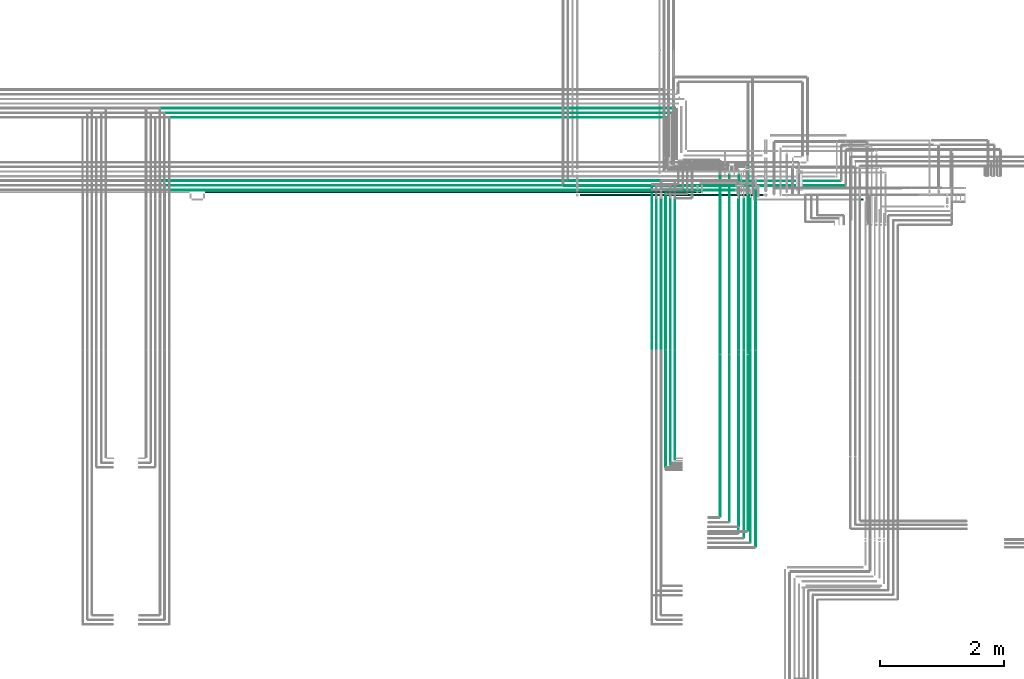
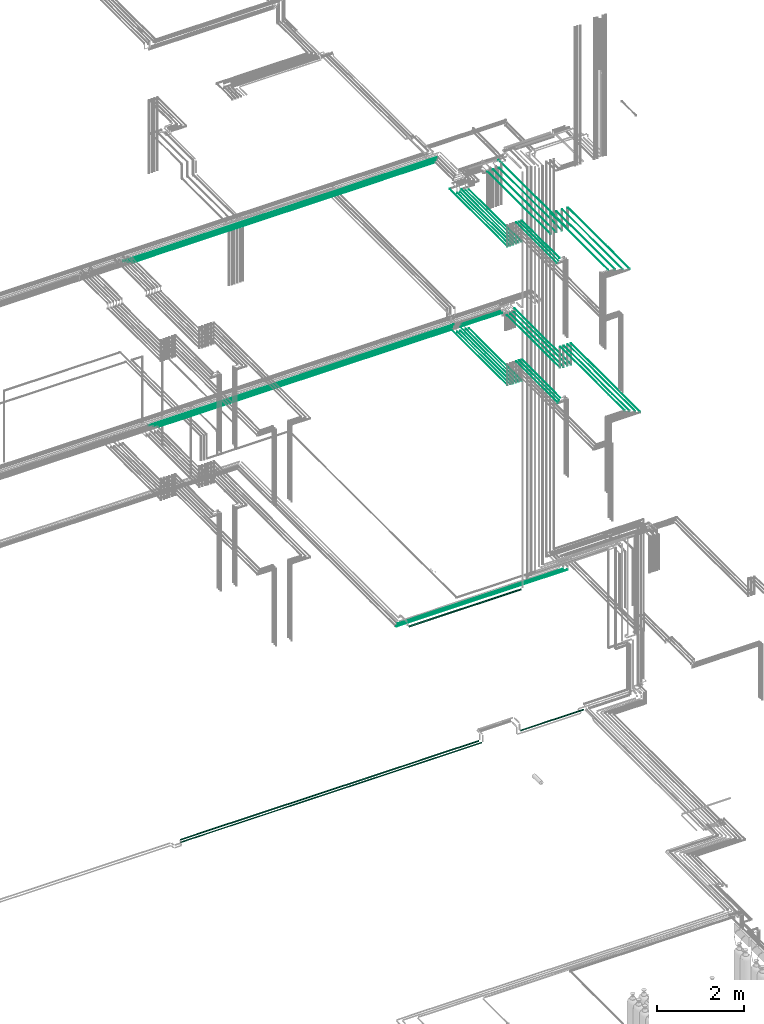
# One storey, part 75 of 331: 48 flow segments.
"""IFC2X3 building model written with IfcOpenShell, lengths in millimetres."""

from ifc_helpers import new_model, entity, si_unit, converted_unit, derived_unit, direction, frame, frame_2d, origin, origin_2d_with_axis, place, context, subcontext, project, spatial, circle, extrude, type_object, element, save


model = new_model("IFC2X3")

# Units and contexts
model_context = context("Model", 3, precision=0.01, world=origin(), true_north=direction((6.12303176911189e-17, 1.0)))
body_context = subcontext(model_context, "Body", "Model", "MODEL_VIEW")
ifc_project = project(units=[si_unit("LENGTHUNIT", "METRE", prefix="MILLI"), si_unit("AREAUNIT", "SQUARE_METRE"), si_unit("VOLUMEUNIT", "CUBIC_METRE"), converted_unit("PLANEANGLEUNIT", "DEGREE", entity("IfcRatioMeasure", 0.0174532925199433), si_unit("PLANEANGLEUNIT", "RADIAN"), dimensions=[0, 0, 0, 0, 0, 0, 0]), si_unit("MASSUNIT", "GRAM", prefix="KILO"), derived_unit("MASSDENSITYUNIT", [(si_unit("MASSUNIT", "GRAM", prefix="KILO"), 1), (si_unit("LENGTHUNIT", "METRE"), -3)]), derived_unit("MOMENTOFINERTIAUNIT", [(si_unit("LENGTHUNIT", "METRE"), 4)]), si_unit("TIMEUNIT", "SECOND"), si_unit("FREQUENCYUNIT", "HERTZ"), si_unit("THERMODYNAMICTEMPERATUREUNIT", "DEGREE_CELSIUS"), derived_unit("THERMALTRANSMITTANCEUNIT", [(si_unit("MASSUNIT", "GRAM", prefix="KILO"), 1), (si_unit("THERMODYNAMICTEMPERATUREUNIT", "KELVIN"), -1), (si_unit("TIMEUNIT", "SECOND"), -3)]), derived_unit("VOLUMETRICFLOWRATEUNIT", [(si_unit("LENGTHUNIT", "METRE"), 3), (si_unit("TIMEUNIT", "SECOND"), -1)]), derived_unit("MASSFLOWRATEUNIT", [(si_unit("MASSUNIT", "GRAM", prefix="KILO"), 1), (si_unit("TIMEUNIT", "SECOND"), -1)]), derived_unit("ROTATIONALFREQUENCYUNIT", [(si_unit("TIMEUNIT", "SECOND"), -1)]), si_unit("ELECTRICCURRENTUNIT", "AMPERE"), si_unit("ELECTRICVOLTAGEUNIT", "VOLT"), si_unit("POWERUNIT", "WATT"), si_unit("FORCEUNIT", "NEWTON", prefix="KILO"), si_unit("ILLUMINANCEUNIT", "LUX"), si_unit("LUMINOUSFLUXUNIT", "LUMEN"), si_unit("LUMINOUSINTENSITYUNIT", "CANDELA"), derived_unit("USERDEFINED", [(si_unit("MASSUNIT", "GRAM", prefix="KILO"), -1), (si_unit("LENGTHUNIT", "METRE"), -2), (si_unit("TIMEUNIT", "SECOND"), 3), (si_unit("LUMINOUSFLUXUNIT", "LUMEN"), 1)]), derived_unit("LINEARVELOCITYUNIT", [(si_unit("LENGTHUNIT", "METRE"), 1), (si_unit("TIMEUNIT", "SECOND"), -1)]), si_unit("PRESSUREUNIT", "PASCAL"), derived_unit("USERDEFINED", [(si_unit("LENGTHUNIT", "METRE"), -2), (si_unit("MASSUNIT", "GRAM", prefix="KILO"), 1), (si_unit("TIMEUNIT", "SECOND"), -2)]), derived_unit("LINEARFORCEUNIT", [(si_unit("MASSUNIT", "GRAM", prefix="KILO"), 1), (si_unit("LENGTHUNIT", "METRE"), 1), (si_unit("TIMEUNIT", "SECOND"), -2), (si_unit("LENGTHUNIT", "METRE"), -1)]), derived_unit("PLANARFORCEUNIT", [(si_unit("MASSUNIT", "GRAM", prefix="KILO"), 1), (si_unit("LENGTHUNIT", "METRE"), 1), (si_unit("TIMEUNIT", "SECOND"), -2), (si_unit("LENGTHUNIT", "METRE"), -2)])], contexts=[model_context])

# Site, building, storey
site_placement = place(None, frame((0.0, -0.00077364408347762, 0.0)))
site = spatial("IfcSite", under=ifc_project, at=site_placement, CompositionType="ELEMENT")
building_placement = place(site_placement, origin())
building = spatial("IfcBuilding", under=site, at=building_placement, CompositionType="ELEMENT")
storey_placement = place(building_placement, origin())
storey = spatial("IfcBuildingStorey", under=building, at=storey_placement, CompositionType="ELEMENT", Elevation=0.0)

# Flow segments
pipe_segment_type = type_object("IfcPipeSegmentType", PredefinedType="NOTDEFINED")
flow_segment_1_placement = place(building_placement, frame((63625.9955203528, 8059.40472776408, 2759.40472776408)))
element("IfcFlowSegment", 1, at=flow_segment_1_placement, inside=storey, type_object=pipe_segment_type, context=body_context, shape_type="SweptSolid", body=[
    extrude(circle(Radius=14.0, at=frame_2d((1.08286712929839e-12, 0.0), x_axis=(1.0, 0.0))), frame((0.0, 15.595272235917, 15.595272235916), z_axis=(1.0, 0.0, 0.0), x_axis=(0.0, 1.0, 0.0)), (0.0, 0.0, 1.0), 1665.11638284115),
])
flow_segment_2_placement = place(storey_placement, frame((63460.8735189448, 5653.62056382735, 14544.4047277641)))
element("IfcFlowSegment", 2, at=flow_segment_2_placement, inside=storey, type_object=pipe_segment_type, context=body_context, shape_type="SweptSolid", body=[
    extrude(circle(Radius=4.0, at=origin_2d_with_axis()), frame((5.59527223591499, 0.0, 5.59527223591499), z_axis=(0.0, 1.0, 0.0), x_axis=(-1.0, 0.0, 0.0)), (0.0, 0.0, 1.0), 2456.00000000002),
])
for number, where in (
    (3, (62090.5225183915, 5653.62056382735, 14544.4047277641)),
    (4, (61865.5225183915, 5653.62056382735, 14544.4047277641)),
):
    element("IfcFlowSegment", number, at=place(storey_placement, frame(where)), inside=storey, type_object=pipe_segment_type, context=body_context, shape_type="SweptSolid", body=[
        extrude(circle(Radius=4.0, at=origin_2d_with_axis()), frame((5.59527223591499, 0.0, 5.59527223591499), z_axis=(0.0, 1.0, 0.0), x_axis=(1.0, 0.0, 0.0)), (0.0, 0.0, 1.0), 2558.99999999999),
    ])
flow_segment_3_placement = place(storey_placement, frame((62103.1177906274, 8218.02529159142, 14542.4047277641)))
element("IfcFlowSegment", 5, at=flow_segment_3_placement, inside=storey, type_object=pipe_segment_type, context=body_context, shape_type="SweptSolid", body=[
    extrude(circle(Radius=6.0, at=frame_2d((-1.08286712929839e-12, 8.78354001618333e-43), x_axis=(1.0, 0.0))), frame((0.0, 7.59527223591454, 7.5952722359167), z_axis=(1.0, 0.0, 0.0), x_axis=(0.0, -1.0, 0.0)), (0.0, 0.0, 1.0), 1108.80729904695),
])
flow_segment_4_placement = place(storey_placement, frame((63351.7906839002, 5643.62056382736, 14542.4047277641)))
element("IfcFlowSegment", 6, at=flow_segment_4_placement, inside=storey, type_object=pipe_segment_type, context=body_context, shape_type="SweptSolid", body=[
    extrude(circle(Radius=6.0, at=origin_2d_with_axis()), frame((7.59527223591454, 0.0, 7.5952722359167), z_axis=(0.0, 1.0, 0.0), x_axis=(-1.0, 0.0, 0.0)), (0.0, 0.0, 1.0), 2443.38938002202),
])
flow_segment_5_placement = place(storey_placement, frame((62178.1163177572, 8293.02529159145, 14542.7704171679)))
element("IfcFlowSegment", 7, at=flow_segment_5_placement, inside=storey, type_object=pipe_segment_type, context=body_context, shape_type="SweptSolid", body=[
    extrude(circle(Radius=6.0, at=origin_2d_with_axis()), frame((0.000126580159098921, 7.59527223591562, 7.59527223458044), z_axis=(1.0, 0.0, 2.10966951283074e-05), x_axis=(0.0, -1.0, 0.0)), (0.0, 0.0, 1.0), 1023.80864557016),
])
for number, where in (
    (8, (62165.5225183915, 5653.62056382735, 14544.4047277641)),
    (9, (61940.5225183915, 5653.62056382735, 14544.4047277641)),
):
    element("IfcFlowSegment", number, at=place(storey_placement, frame(where)), inside=storey, type_object=pipe_segment_type, context=body_context, shape_type="SweptSolid", body=[
        extrude(circle(Radius=4.0, at=origin_2d_with_axis()), frame((5.59527223591499, 0.0, 5.59527223591499), z_axis=(0.0, 1.0, 0.0), x_axis=(-1.0, 0.0, 0.0)), (0.0, 0.0, 1.0), 2427.38938002197),
    ])
flow_segment_6_placement = place(storey_placement, frame((63262.1765027261, 5657.62056382735, 14542.7921403887)))
element("IfcFlowSegment", 10, at=flow_segment_6_placement, inside=storey, type_object=pipe_segment_type, context=body_context, shape_type="SweptSolid", body=[
    extrude(circle(Radius=6.0, at=frame_2d((1.73258740687743e-11, 2.16573425859679e-12), x_axis=(1.0, 0.0))), frame((7.59527223593186, 0.0, 7.59527223591454), z_axis=(0.0, 1.0, 0.0), x_axis=(-1.0, 0.0, 0.0)), (0.0, 0.0, 1.0), 2423.99999999999),
])
flow_segment_7_placement = place(storey_placement, frame((62238.5225183915, 5657.62056382736, 14542.4047277641)))
element("IfcFlowSegment", 11, at=flow_segment_7_placement, inside=storey, type_object=pipe_segment_type, context=body_context, shape_type="SweptSolid", body=[
    extrude(circle(Radius=6.0, at=frame_2d((0.0, 2.16573425859679e-12), x_axis=(1.0, 0.0))), frame((7.59527223591454, 0.0, 7.59527223591454), z_axis=(0.0, 1.0, 0.0), x_axis=(-1.0, 0.0, 0.0)), (0.0, 0.0, 1.0), 2419.00000000001),
])
flow_segment_8_placement = place(storey_placement, frame((62013.5225183915, 5657.62056382735, 14542.4047277641)))
element("IfcFlowSegment", 12, at=flow_segment_8_placement, inside=storey, type_object=pipe_segment_type, context=body_context, shape_type="SweptSolid", body=[
    extrude(circle(Radius=6.0, at=origin_2d_with_axis()), frame((7.59527223591454, 0.0, 7.5952722359167), z_axis=(0.0, 1.0, 0.0), x_axis=(-1.0, 0.0, 0.0)), (0.0, 0.0, 1.0), 2419.00000000001),
])
flow_segment_9_placement = place(storey_placement, frame((63544.1958799762, 5643.62056382736, 14542.4047277641)))
element("IfcFlowSegment", 13, at=flow_segment_9_placement, inside=storey, type_object=pipe_segment_type, context=body_context, shape_type="SweptSolid", body=[
    extrude(circle(Radius=6.0, at=origin_2d_with_axis()), frame((7.59527223591454, 0.0, 7.5952722359167), z_axis=(0.0, 1.0, 0.0), x_axis=(-1.0, 0.0, 0.0)), (0.0, 0.0, 1.0), 2585.57104510016),
])
flow_segment_10_placement = place(storey_placement, frame((63262.1765027262, 2682.62056382736, 15142.4047277641)))
element("IfcFlowSegment", 14, at=flow_segment_10_placement, inside=storey, type_object=pipe_segment_type, context=body_context, shape_type="SweptSolid", body=[
    extrude(circle(Radius=6.0, at=frame_2d((0.0, -2.16573425859679e-12), x_axis=(1.0, 0.0))), frame((7.59527223590587, 0.0, 7.59527223591454), z_axis=(0.0, 1.0, 0.0), x_axis=(1.0, 0.0, 0.0)), (0.0, 0.0, 1.0), 2947.0),
])
flow_segment_11_placement = place(storey_placement, frame((63351.7906839002, 2607.62056382736, 15142.4047277641)))
element("IfcFlowSegment", 15, at=flow_segment_11_placement, inside=storey, type_object=pipe_segment_type, context=body_context, shape_type="SweptSolid", body=[
    extrude(circle(Radius=6.0, at=frame_2d((8.66293703438714e-12, 2.16573425859679e-12), x_axis=(1.0, 0.0))), frame((7.59527223591454, 0.0, 7.59527223591454), z_axis=(0.0, 1.0, 0.0), x_axis=(-1.0, 0.0, 0.0)), (0.0, 0.0, 1.0), 3022.00000000001),
])
flow_segment_12_placement = place(storey_placement, frame((63544.1958799762, 2457.62056382735, 15142.4047277641)))
element("IfcFlowSegment", 16, at=flow_segment_12_placement, inside=storey, type_object=pipe_segment_type, context=body_context, shape_type="SweptSolid", body=[
    extrude(circle(Radius=6.0, at=frame_2d((0.0, 2.16573425859679e-12), x_axis=(1.0, 0.0))), frame((7.59527223591454, 0.0, 7.59527223591454), z_axis=(0.0, 1.0, 0.0), x_axis=(-1.0, 0.0, 0.0)), (0.0, 0.0, 1.0), 3172.00000000001),
])
flow_segment_13_placement = place(storey_placement, frame((63460.8735189448, 2528.62056382736, 15144.4047277641)))
element("IfcFlowSegment", 17, at=flow_segment_13_placement, inside=storey, type_object=pipe_segment_type, context=body_context, shape_type="SweptSolid", body=[
    extrude(circle(Radius=4.0, at=frame_2d((8.66293703438714e-12, 0.0), x_axis=(1.0, 0.0))), frame((5.59527223591499, 0.0, 5.59527223591499), z_axis=(0.0, 1.0, 0.0), x_axis=(-1.0, 0.0, 0.0)), (0.0, 0.0, 1.0), 3105.00000000001),
])
flow_segment_14_placement = place(storey_placement, frame((62238.5225183915, 3869.0, 15142.4047277641)))
element("IfcFlowSegment", 18, at=flow_segment_14_placement, inside=storey, type_object=pipe_segment_type, context=body_context, shape_type="SweptSolid", body=[
    extrude(circle(Radius=6.0, at=frame_2d((0.0, -2.16573425859679e-12), x_axis=(1.0, 0.0))), frame((7.59527223591454, 0.0, 7.59527223591454), z_axis=(0.0, 1.0, 0.0), x_axis=(1.0, 0.0, 0.0)), (0.0, 0.0, 1.0), 1760.62056382721),
])
flow_segment_15_placement = place(storey_placement, frame((62165.5225183915, 3790.0, 15144.4047277641)))
element("IfcFlowSegment", 19, at=flow_segment_15_placement, inside=storey, type_object=pipe_segment_type, context=body_context, shape_type="SweptSolid", body=[
    extrude(circle(Radius=4.0, at=origin_2d_with_axis()), frame((5.59527223591499, 0.0, 5.59527223591499), z_axis=(0.0, 1.0, 0.0), x_axis=(1.0, 0.0, 0.0)), (0.0, 0.0, 1.0), 1843.6205638272),
])
flow_segment_16_placement = place(storey_placement, frame((62090.5225183915, 3715.0, 15144.4047277641)))
element("IfcFlowSegment", 20, at=flow_segment_16_placement, inside=storey, type_object=pipe_segment_type, context=body_context, shape_type="SweptSolid", body=[
    extrude(circle(Radius=4.0, at=origin_2d_with_axis()), frame((5.59527223591499, 0.0, 5.59527223591499), z_axis=(0.0, 1.0, 0.0), x_axis=(1.0, 0.0, 0.0)), (0.0, 0.0, 1.0), 1918.62056382721),
])
flow_segment_17_placement = place(storey_placement, frame((54078.1176040737, 8218.02529159142, 14542.4047277641)))
element("IfcFlowSegment", 21, at=flow_segment_17_placement, inside=storey, type_object=pipe_segment_type, context=body_context, shape_type="SweptSolid", body=[
    extrude(circle(Radius=6.0, at=origin_2d_with_axis()), frame((0.0, 7.5952722359232, 7.5952722359167), z_axis=(1.0, 0.0, 0.0), x_axis=(0.0, -1.0, 0.0)), (0.0, 0.0, 1.0), 7786.00018655369),
])
flow_segment_18_placement = place(storey_placement, frame((54003.1156081152, 8293.02529159145, 14542.5981199607)))
element("IfcFlowSegment", 22, at=flow_segment_18_placement, inside=storey, type_object=pipe_segment_type, context=body_context, shape_type="SweptSolid", body=[
    extrude(circle(Radius=6.0, at=origin_2d_with_axis()), frame((0.000126456651605622, 7.59527223591562, 7.59527223458261), z_axis=(1.0, 0.0, 2.10761091341828e-05), x_axis=(0.0, -1.0, 0.0)), (0.0, 0.0, 1.0), 7936.00071163218),
])
flow_segment_19_placement = place(storey_placement, frame((53929.1155492238, 8366.52529159144, 14541.1108396014)))
element("IfcFlowSegment", 23, at=flow_segment_19_placement, inside=storey, type_object=pipe_segment_type, context=body_context, shape_type="SweptSolid", body=[
    extrude(circle(Radius=7.5, at=origin_2d_with_axis()), frame((0.000168554696574574, 9.09527223591636, 9.09527223402134), z_axis=(1.0, 0.0, 2.24739589679482e-05), x_axis=(0.0, -1.0, 0.0)), (0.0, 0.0, 1.0), 8084.00074704571),
])
flow_segment_20_placement = place(storey_placement, frame((63417.0166110417, 5587.94357694349, 18440.9047277641)))
element("IfcFlowSegment", 24, at=flow_segment_20_placement, inside=storey, type_object=pipe_segment_type, context=body_context, shape_type="SweptSolid", body=[
    extrude(circle(Radius=7.5, at=frame_2d((-1.73258740687743e-11, 0.0), x_axis=(1.0, 0.0))), frame((9.09527223592286, 0.0, 9.09527223591636), z_axis=(0.0, 1.0, 0.0), x_axis=(-1.0, 0.0, 0.0)), (0.0, 0.0, 1.0), 3154.86715753866),
])
flow_segment_21_placement = place(building_placement, frame((54654.2054191312, 8182.92098945658, 2687.40472776403)))
element("IfcFlowSegment", 25, at=flow_segment_21_placement, inside=storey, type_object=pipe_segment_type, context=body_context, shape_type="SweptSolid", body=[
    extrude(circle(Radius=11.0, at=origin_2d_with_axis()), frame((0.0, 12.5952722360715, 12.5952722359161), z_axis=(1.0, 0.0, 0.0), x_axis=(0.0, -1.0, 0.0)), (0.0, 0.0, 1.0), 8004.79254262788),
])
flow_segment_22_placement = place(storey_placement, frame((63270.5166110417, 5579.94357694349, 18444.4047277641)))
element("IfcFlowSegment", 26, at=flow_segment_22_placement, inside=storey, type_object=pipe_segment_type, context=body_context, shape_type="SweptSolid", body=[
    extrude(circle(Radius=4.0, at=frame_2d((0.0, 1.78239929482515e-09), x_axis=(1.0, 0.0))), frame((5.59527223591499, 0.0, 5.59527223769739), z_axis=(0.0, 1.0, 0.0), x_axis=(-1.0, 0.0, 0.0)), (0.0, 0.0, 1.0), 2891.86715753895),
])
flow_segment_23_placement = place(storey_placement, frame((63118.5166110417, 5583.94357694349, 18442.4047277641)))
element("IfcFlowSegment", 27, at=flow_segment_23_placement, inside=storey, type_object=pipe_segment_type, context=body_context, shape_type="SweptSolid", body=[
    extrude(circle(Radius=6.0, at=frame_2d((0.0, 1.70010139299848e-09), x_axis=(1.0, 0.0))), frame((7.59527223591454, 0.0, 7.59527223761897), z_axis=(0.0, 1.0, 0.0), x_axis=(-1.0, 0.0, 0.0)), (0.0, 0.0, 1.0), 2893.86715753895),
])
flow_segment_24_placement = place(storey_placement, frame((62968.5166110417, 5583.94357694349, 18442.4047277641)))
element("IfcFlowSegment", 28, at=flow_segment_24_placement, inside=storey, type_object=pipe_segment_type, context=body_context, shape_type="SweptSolid", body=[
    extrude(circle(Radius=6.0, at=frame_2d((-8.66293703438714e-12, 0.0), x_axis=(1.0, 0.0))), frame((7.59527223590587, 0.0, 7.5952722359167), z_axis=(0.0, 1.0, 0.0), x_axis=(-1.0, 0.0, 0.0)), (0.0, 0.0, 1.0), 2886.86715753895),
])
flow_segment_25_placement = place(storey_placement, frame((62968.5166110417, 2943.9435769435, 19042.4047277641)))
element("IfcFlowSegment", 29, at=flow_segment_25_placement, inside=storey, type_object=pipe_segment_type, context=body_context, shape_type="SweptSolid", body=[
    extrude(circle(Radius=6.0, at=frame_2d((8.66293703438714e-12, 0.0), x_axis=(1.0, 0.0))), frame((7.5952722359232, 0.0, 7.5952722359167), z_axis=(0.0, 1.0, 0.0), x_axis=(-1.0, 0.0, 0.0)), (0.0, 0.0, 1.0), 2612.00000000001),
])
flow_segment_26_placement = place(storey_placement, frame((63118.5166110417, 2868.9435769435, 19042.4047277641)))
element("IfcFlowSegment", 30, at=flow_segment_26_placement, inside=storey, type_object=pipe_segment_type, context=body_context, shape_type="SweptSolid", body=[
    extrude(circle(Radius=6.0, at=origin_2d_with_axis()), frame((7.59527223591454, 0.0, 7.5952722359167), z_axis=(0.0, 1.0, 0.0), x_axis=(-1.0, 0.0, 0.0)), (0.0, 0.0, 1.0), 2687.00000000001),
])
flow_segment_27_placement = place(storey_placement, frame((63270.5166110417, 2789.94357694349, 19044.4047277641)))
element("IfcFlowSegment", 31, at=flow_segment_27_placement, inside=storey, type_object=pipe_segment_type, context=body_context, shape_type="SweptSolid", body=[
    extrude(circle(Radius=4.0, at=origin_2d_with_axis()), frame((5.59527223591499, 0.0, 5.59527223591499), z_axis=(0.0, 1.0, 0.0), x_axis=(-1.0, 0.0, 0.0)), (0.0, 0.0, 1.0), 2770.00000000001),
])
flow_segment_28_placement = place(storey_placement, frame((63417.0166110417, 2722.94357694349, 19040.9047277641)))
element("IfcFlowSegment", 32, at=flow_segment_28_placement, inside=storey, type_object=pipe_segment_type, context=body_context, shape_type="SweptSolid", body=[
    extrude(circle(Radius=7.5, at=origin_2d_with_axis()), frame((9.09527223591419, 0.0, 9.09527223591636), z_axis=(0.0, 1.0, 0.0), x_axis=(-1.0, 0.0, 0.0)), (0.0, 0.0, 1.0), 2829.0),
])
flow_segment_29_placement = place(storey_placement, frame((62089.4468045266, 5653.62056382728, 18444.404727764)))
element("IfcFlowSegment", 33, at=flow_segment_29_placement, inside=storey, type_object=pipe_segment_type, context=body_context, shape_type="SweptSolid", body=[
    extrude(circle(Radius=4.0, at=origin_2d_with_axis()), frame((5.59527223591499, 0.0, 5.59527223591499), z_axis=(0.0, 1.0, 0.0), x_axis=(1.0, 0.0, 0.0)), (0.0, 0.0, 1.0), 2501.52824282759),
])
flow_segment_30_placement = place(storey_placement, frame((61864.4468045266, 5653.62056382728, 18444.4047277641)))
element("IfcFlowSegment", 34, at=flow_segment_30_placement, inside=storey, type_object=pipe_segment_type, context=body_context, shape_type="SweptSolid", body=[
    extrude(circle(Radius=4.0, at=frame_2d((8.66293703438714e-12, 0.0), x_axis=(1.0, 0.0))), frame((5.59527223592365, 0.0, 5.59527223591499), z_axis=(0.0, 1.0, 0.0), x_axis=(-1.0, 0.0, 0.0)), (0.0, 0.0, 1.0), 2651.5282428276),
])
flow_segment_31_placement = place(storey_placement, frame((62164.4468045266, 5653.62056382729, 18444.4047277641)))
element("IfcFlowSegment", 35, at=flow_segment_31_placement, inside=storey, type_object=pipe_segment_type, context=body_context, shape_type="SweptSolid", body=[
    extrude(circle(Radius=4.0, at=origin_2d_with_axis()), frame((5.59527223591499, 0.0, 5.59527223591499), z_axis=(0.0, 1.0, 0.0), x_axis=(1.0, 0.0, 0.0)), (0.0, 0.0, 1.0), 2426.5282428276),
])
flow_segment_32_placement = place(storey_placement, frame((61939.4468045266, 5653.62056382729, 18444.4047277641)))
element("IfcFlowSegment", 36, at=flow_segment_32_placement, inside=storey, type_object=pipe_segment_type, context=body_context, shape_type="SweptSolid", body=[
    extrude(circle(Radius=4.0, at=origin_2d_with_axis()), frame((5.59527223591499, 0.0, 5.59527223591499), z_axis=(0.0, 1.0, 0.0), x_axis=(-1.0, 0.0, 0.0)), (0.0, 0.0, 1.0), 2426.52824282759),
])
flow_segment_33_placement = place(storey_placement, frame((62237.4468045266, 5657.6205638273, 18442.4047277641)))
element("IfcFlowSegment", 37, at=flow_segment_33_placement, inside=storey, type_object=pipe_segment_type, context=body_context, shape_type="SweptSolid", body=[
    extrude(circle(Radius=6.0, at=origin_2d_with_axis()), frame((7.59527223591454, 0.0, 7.5952722359167), z_axis=(0.0, 1.0, 0.0), x_axis=(1.0, 0.0, 0.0)), (0.0, 0.0, 1.0), 2418.52824282759),
])
flow_segment_34_placement = place(storey_placement, frame((62012.4468045266, 5657.62056382729, 18442.4047277641)))
element("IfcFlowSegment", 38, at=flow_segment_34_placement, inside=storey, type_object=pipe_segment_type, context=body_context, shape_type="SweptSolid", body=[
    extrude(circle(Radius=6.0, at=origin_2d_with_axis()), frame((7.59527223591454, 0.0, 7.5952722359167), z_axis=(0.0, 1.0, 0.0), x_axis=(1.0, 0.0, 0.0)), (0.0, 0.0, 1.0), 2418.52824282761),
])
flow_segment_35_placement = place(storey_placement, frame((62237.4468045266, 3905.48876707964, 19042.4047277641)))
element("IfcFlowSegment", 39, at=flow_segment_35_placement, inside=storey, type_object=pipe_segment_type, context=body_context, shape_type="SweptSolid", body=[
    extrude(circle(Radius=6.0, at=origin_2d_with_axis()), frame((7.59527223591454, 0.0, 7.5952722359167), z_axis=(0.0, 1.0, 0.0), x_axis=(1.0, 0.0, 0.0)), (0.0, 0.0, 1.0), 1724.13179674766),
])
flow_segment_36_placement = place(storey_placement, frame((62164.4468045266, 3826.48876707963, 19044.4047277641)))
element("IfcFlowSegment", 40, at=flow_segment_36_placement, inside=storey, type_object=pipe_segment_type, context=body_context, shape_type="SweptSolid", body=[
    extrude(circle(Radius=4.0, at=origin_2d_with_axis()), frame((5.59527223591499, 0.0, 5.59527223591499), z_axis=(0.0, 1.0, 0.0), x_axis=(1.0, 0.0, 0.0)), (0.0, 0.0, 1.0), 1807.13179674766),
])
flow_segment_37_placement = place(storey_placement, frame((62089.4468045266, 3751.48876707963, 19044.4047277641)))
element("IfcFlowSegment", 41, at=flow_segment_37_placement, inside=storey, type_object=pipe_segment_type, context=body_context, shape_type="SweptSolid", body=[
    extrude(circle(Radius=4.0, at=origin_2d_with_axis()), frame((5.59527223591499, 0.0, 5.59527223591499), z_axis=(0.0, 1.0, 0.0), x_axis=(1.0, 0.0, 0.0)), (0.0, 0.0, 1.0), 1882.13179674766),
])
flow_segment_38_placement = place(storey_placement, frame((53928.1659203727, 9540.90472776398, 18440.9047277641)))
element("IfcFlowSegment", 42, at=flow_segment_38_placement, inside=storey, type_object=pipe_segment_type, context=body_context, shape_type="SweptSolid", body=[
    extrude(circle(Radius=7.5, at=frame_2d((-3.89832166547421e-11, 2.16573425859679e-12), x_axis=(1.0, 0.0))), frame((0.0, 9.09527223595534, 9.09527223591419), z_axis=(1.0, 0.0, 0.0), x_axis=(0.0, 1.0, 0.0)), (0.0, 0.0, 1.0), 8324.35843205905),
])
flow_segment_39_placement = place(storey_placement, frame((54002.1659203728, 9467.404727764, 18442.4047277641)))
element("IfcFlowSegment", 43, at=flow_segment_39_placement, inside=storey, type_object=pipe_segment_type, context=body_context, shape_type="SweptSolid", body=[
    extrude(circle(Radius=6.0, at=frame_2d((5.41433564649196e-12, 2.16573425859679e-12), x_axis=(1.0, 0.0))), frame((0.0, 7.59527223592103, 7.59527223591454), z_axis=(1.0, 0.0, 0.0), x_axis=(0.0, 1.0, 0.0)), (0.0, 0.0, 1.0), 8179.35843205903),
])
flow_segment_40_placement = place(storey_placement, frame((54077.1659203728, 9392.404727764, 18442.4047277642)))
element("IfcFlowSegment", 44, at=flow_segment_40_placement, inside=storey, type_object=pipe_segment_type, context=body_context, shape_type="SweptSolid", body=[
    extrude(circle(Radius=6.0, at=frame_2d((4.33146851719357e-12, 0.0), x_axis=(1.0, 0.0))), frame((0.0, 7.59527223592212, 7.5952722359167), z_axis=(1.0, 0.0, 0.0), x_axis=(0.0, 1.0, 0.0)), (0.0, 0.0, 1.0), 8029.35843205902),
])
flow_segment_41_placement = place(building_placement, frame((60453.9967651366, 8290.39243233188, 6667.40472776409)))
element("IfcFlowSegment", 45, at=flow_segment_41_placement, inside=storey, type_object=pipe_segment_type, context=body_context, shape_type="SweptSolid", body=[
    extrude(circle(Radius=6.0, at=frame_2d((1.62430069394759e-11, 0.0), x_axis=(1.0, 0.0))), frame((0.0, 7.59527223593403, 7.59527223591562), z_axis=(1.0, 0.0, 0.0), x_axis=(0.0, 1.0, 0.0)), (0.0, 0.0, 1.0), 4542.10852392355),
])
flow_segment_42_placement = place(building_placement, frame((60528.9967651366, 8365.39243233187, 6667.40472776409)))
element("IfcFlowSegment", 46, at=flow_segment_42_placement, inside=storey, type_object=pipe_segment_type, context=body_context, shape_type="SweptSolid", body=[
    extrude(circle(Radius=6.0, at=frame_2d((2.4905943973863e-11, 0.0), x_axis=(1.0, 0.0))), frame((0.0, 7.59527223593944, 7.59527223591562), z_axis=(1.0, 0.0, 0.0), x_axis=(0.0, 1.0, 0.0)), (0.0, 0.0, 1.0), 4392.10852392355),
])
flow_segment_43_placement = place(storey_placement, frame((60704.9967651366, 8128.83499464517, 6655.90472776406)))
element("IfcFlowSegment", 47, at=flow_segment_43_placement, inside=storey, type_object=pipe_segment_type, context=body_context, shape_type="SweptSolid", body=[
    extrude(circle(Radius=17.5, at=origin_2d_with_axis()), frame((0.0, 19.0952722359163, 19.0952722359163), z_axis=(1.0, 0.0, 0.0), x_axis=(0.0, -1.0, 0.0)), (0.0, 0.0, 1.0), 2967.61511814097),
])
flow_segment_44_placement = place(building_placement, frame((54664.2054191312, 8179.92098945658, 2759.40472776402)))
element("IfcFlowSegment", 48, at=flow_segment_44_placement, inside=storey, type_object=pipe_segment_type, context=body_context, shape_type="SweptSolid", body=[
    extrude(circle(Radius=14.0, at=frame_2d((1.08286712929839e-12, 0.0), x_axis=(1.0, 0.0))), frame((0.0, 15.5952722359192, 15.595272235916), z_axis=(1.0, 0.0, 0.0), x_axis=(0.0, -1.0, 0.0)), (0.0, 0.0, 1.0), 7909.7925426279),
])

save(model, "model.ifc")
